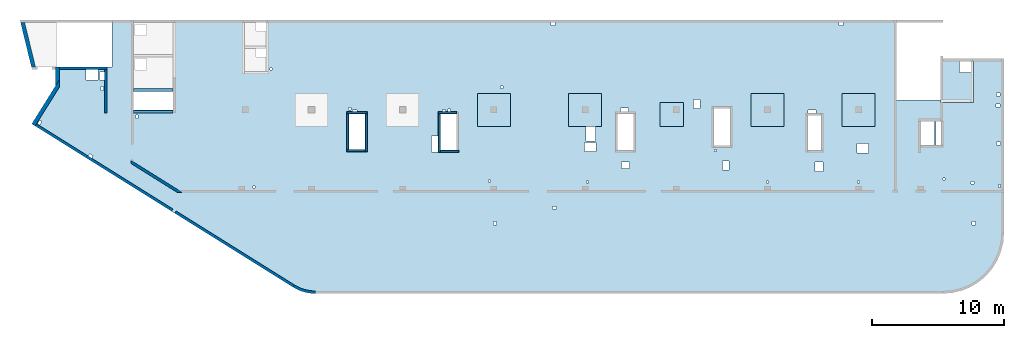
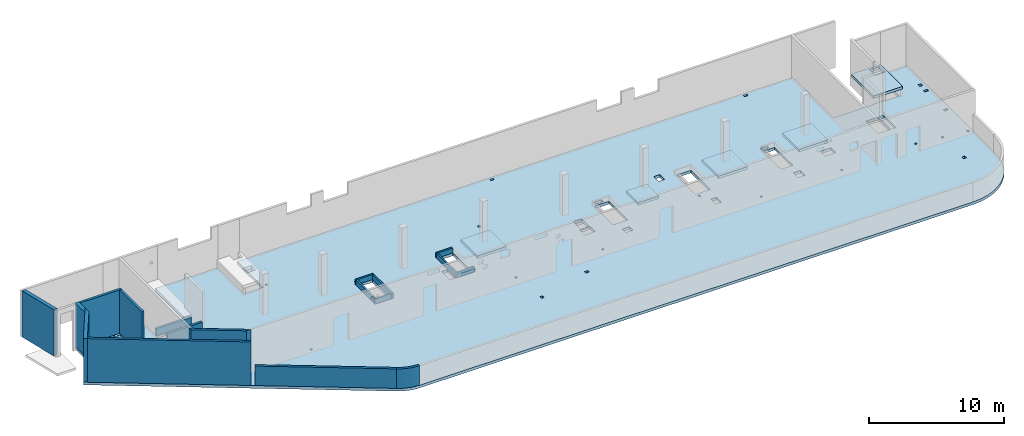
# One storey, part 2 of 6: 18 walls, 7 slabs.
"""IFC4 building model written with IfcOpenShell, lengths in millimetres."""

from ifc_helpers import new_model, entity, si_unit, converted_unit, derived_unit, direction, frame, origin, place, context, subcontext, project, spatial, indexed_curve, outline, extrude, material, type_object, element, save


model = new_model("IFC4")

# Units and contexts
model_context = context("Model", 3, precision=0.01, world=origin(), true_north=direction((6.12303176911189e-17, 1.0)))
plan_context = context("Plan", 3, precision=0.01, world=origin(), true_north=direction((6.12303176911189e-17, 1.0)))
body_context = subcontext(model_context, "Body", "Model", "MODEL_VIEW")
ifc_project = project(units=[si_unit("LENGTHUNIT", "METRE", prefix="MILLI"), si_unit("AREAUNIT", "SQUARE_METRE"), si_unit("VOLUMEUNIT", "CUBIC_METRE"), converted_unit("PLANEANGLEUNIT", "DEGREE", entity("IfcRatioMeasure", 0.0174532925199433), si_unit("PLANEANGLEUNIT", "RADIAN"), dimensions=[0, 0, 0, 0, 0, 0, 0]), si_unit("MASSUNIT", "GRAM", prefix="KILO"), derived_unit("MASSDENSITYUNIT", [(si_unit("MASSUNIT", "GRAM", prefix="KILO"), 1), (si_unit("LENGTHUNIT", "METRE"), -3)]), derived_unit("MOMENTOFINERTIAUNIT", [(si_unit("LENGTHUNIT", "METRE"), 4)]), si_unit("TIMEUNIT", "SECOND"), si_unit("FREQUENCYUNIT", "HERTZ"), si_unit("THERMODYNAMICTEMPERATUREUNIT", "DEGREE_CELSIUS"), derived_unit("THERMALTRANSMITTANCEUNIT", [(si_unit("MASSUNIT", "GRAM", prefix="KILO"), 1), (si_unit("THERMODYNAMICTEMPERATUREUNIT", "KELVIN"), -1), (si_unit("TIMEUNIT", "SECOND"), -3)]), derived_unit("VOLUMETRICFLOWRATEUNIT", [(si_unit("LENGTHUNIT", "METRE"), 3), (si_unit("TIMEUNIT", "SECOND"), -1)]), derived_unit("MASSFLOWRATEUNIT", [(si_unit("MASSUNIT", "GRAM", prefix="KILO"), 1), (si_unit("TIMEUNIT", "SECOND"), -1)]), derived_unit("ROTATIONALFREQUENCYUNIT", [(si_unit("TIMEUNIT", "SECOND"), -1)]), si_unit("ELECTRICCURRENTUNIT", "AMPERE"), si_unit("ELECTRICVOLTAGEUNIT", "VOLT"), si_unit("POWERUNIT", "WATT"), si_unit("FORCEUNIT", "NEWTON", prefix="KILO"), si_unit("ILLUMINANCEUNIT", "LUX"), si_unit("LUMINOUSFLUXUNIT", "LUMEN"), si_unit("LUMINOUSINTENSITYUNIT", "CANDELA"), derived_unit("USERDEFINED", [(si_unit("MASSUNIT", "GRAM", prefix="KILO"), -1), (si_unit("LENGTHUNIT", "METRE"), -2), (si_unit("TIMEUNIT", "SECOND"), 3), (si_unit("LUMINOUSFLUXUNIT", "LUMEN"), 1)]), derived_unit("LINEARVELOCITYUNIT", [(si_unit("LENGTHUNIT", "METRE"), 1), (si_unit("TIMEUNIT", "SECOND"), -1)]), si_unit("PRESSUREUNIT", "PASCAL"), derived_unit("USERDEFINED", [(si_unit("LENGTHUNIT", "METRE"), -2), (si_unit("MASSUNIT", "GRAM", prefix="KILO"), 1), (si_unit("TIMEUNIT", "SECOND"), -2)]), derived_unit("LINEARFORCEUNIT", [(si_unit("MASSUNIT", "GRAM", prefix="KILO"), 1), (si_unit("LENGTHUNIT", "METRE"), 1), (si_unit("TIMEUNIT", "SECOND"), -2), (si_unit("LENGTHUNIT", "METRE"), -1)]), derived_unit("PLANARFORCEUNIT", [(si_unit("MASSUNIT", "GRAM", prefix="KILO"), 1), (si_unit("LENGTHUNIT", "METRE"), 1), (si_unit("TIMEUNIT", "SECOND"), -2), (si_unit("LENGTHUNIT", "METRE"), -2)])], contexts=[model_context, plan_context])

# Site, building, storey
site_placement = place(None, origin())
site = spatial("IfcSite", under=ifc_project, at=site_placement, CompositionType="ELEMENT")
building_placement = place(site_placement, origin())
building = spatial("IfcBuilding", under=site, at=building_placement, CompositionType="ELEMENT")
storey_placement = place(building_placement, frame((0.0, 0.0, 28200.0)))
storey = spatial("IfcBuildingStorey", under=building, at=storey_placement, Name="08", CompositionType="ELEMENT", Elevation=28200.0)

# Slabs
ifc_material = material()
slab_type_1 = type_object("IfcSlabType", Name=":ADSK_ 25_250", PredefinedType="FLOOR", material=ifc_material)
placement = place(storey_placement, origin())
element("IfcSlab", 1, at=placement, inside=storey, type_object=slab_type_1, material=ifc_material, Name=":ADSK_ 25_250", ObjectType=":ADSK_ 25_250", PredefinedType="FLOOR", context=body_context, shape_type="SweptSolid", body=[
    extrude(outline(indexed_curve([(-9938.81931383592, -15994.6889933943), (-9785.18945223826, -16084.8814308087), (-9626.77631531153, -16166.380438105), (-9464.0713398645, -16238.9331851656), (-9297.57927705262, -16302.3145953889), (-9127.81662651489, -16356.3280439333), (-8955.31003406395, -16400.8059676958), (-8780.59465790024, -16435.6103851342), (-8604.21250841868, -16460.6333243205), (-8426.71076675808, -16475.797157896), (-8248.64008730964, -16481.0548438912), (39261.8400680731, -16481.0548438912), (39981.4384793149, -16424.4212206982), (40683.3179894618, -16255.9148588784), (41350.1959955693, -15979.6849443003), (41965.6517478859, -15602.5331742155), (42514.530683209, -15133.7462768982), (42983.3175805262, -14584.8673415751), (43360.4693506111, -13969.4115892585), (43636.6992651892, -13302.533583151), (43805.205627009, -12600.6540730041), (43861.839250202, -11881.0556617623), (43861.839250202, 1288.94433823765), (41361.839250202, 1288.94433823766), (41361.839250202, -1811.05566176234), (39061.8400680731, -1811.05566176233), (39061.8400680731, -1851.05566176232), (35721.8400680731, -1851.05566176231), (35721.8400680732, 4218.94497760487), (-11983.1599319269, 4218.94497760503), (-11983.1599319269, 318.944338238026), (-13608.1599319269, 318.944338238032), (-13608.1599319269, 4218.94497760487), (-19008.1599319269, 4218.94497760488), (-19008.1599319269, -981.05502239514), (-22008.1599319269, -981.055022395131), (-22008.1599319269, 4218.94497760487), (-23638.1599319269, 4218.94497760487), (-23638.1599319269, 678.944338238106), (-27903.1599319269, 678.944338238122), (-27903.1599319269, -752.702496972901), (-29708.3002878078, -3641.58731781876), (-9938.81931383592, -15994.6889933943)], self_intersect=False), holes=[indexed_curve([(-24693.1599319269, 478.944338238115), (-24693.1599319269, -321.055661761885), (-25623.1599319269, -321.055661761885), (-25623.1599319269, 478.944338238115), (-24693.1599319269, 478.944338238115)], self_intersect=False), indexed_curve([(-24573.1599319269, -311.055661761892), (-24573.1599319269, 288.944338238108), (-24208.1599319269, 288.944338238108), (-24208.1599319269, -311.055661761892), (-24573.1599319269, -311.055661761892)], self_intersect=False), indexed_curve([(-24268.1599319269, -821.055661761893), (-24268.1599319269, -1121.05566176189), (-24468.1599319269, -1121.05566176189), (-24468.1599319269, -821.055661761893), (-24268.1599319269, -821.055661761893)], self_intersect=False), indexed_curve([(-29120.030322959, -3360.6274479853), (-28950.4197742035, -3466.6098132677), (-29109.3933221271, -3721.02563640098), (-29279.0038708826, -3615.04327111857), (-29120.030322959, -3360.6274479853)], self_intersect=False), indexed_curve([(-25332.3965852951, -5904.23328799078), (-25077.9807621618, -6063.20683591438), (-25183.9631274442, -6232.8173846699), (-25438.3789505775, -6073.84383674629), (-25332.3965852951, -5904.23328799078)], self_intersect=False), indexed_curve([(-21683.1599319269, -2966.05566176191), (-21683.1599319269, -3216.05566176191), (-21833.1599319269, -3216.05566176191), (-21833.1599319269, -2966.05566176191), (-21683.1599319269, -2966.05566176191)], self_intersect=False), indexed_curve([(-11548.1599319269, 573.944338238028), (-11548.1599319269, 423.944338238028), (-11698.1599319269, 423.944338238028), (-11698.1599319269, 573.944338238028), (-11548.1599319269, 573.944338238028)], self_intersect=False), indexed_curve([(43571.839250202, -2146.05566176235), (43571.839250202, -2346.05566176235), (43271.839250202, -2346.05566176235), (43271.839250202, -2146.05566176236), (43571.839250202, -2146.05566176235)], self_intersect=False), indexed_curve([(43561.839250202, -1291.05566176236), (43561.839250202, -1541.05566176236), (43311.839250202, -1541.05566176235), (43311.839250202, -1291.05566176236), (43561.839250202, -1291.05566176236)], self_intersect=False), indexed_curve([(43611.839250202, -5031.05566176235), (43611.839250202, -5231.05566176235), (43311.839250202, -5231.05566176235), (43311.839250202, -5031.05566176235), (43611.839250202, -5031.05566176235)], self_intersect=False), indexed_curve([(43586.839250202, -8246.05566176236), (43586.839250202, -8446.05566176236), (43436.839250202, -8446.05566176236), (43436.839250202, -8246.05566176236), (43586.839250202, -8246.05566176236)], self_intersect=False), indexed_curve([(41581.839250202, -7991.05566176235), (41581.839250202, -8191.05566176235), (41381.839250202, -8191.05566176235), (41381.839250202, -7991.05566176235), (41581.839250202, -7991.05566176235)], self_intersect=False), indexed_curve([(39396.8400680731, -7746.05566176233), (39396.8400680731, -7896.05566176233), (39246.8400680731, -7896.05566176233), (39246.8400680731, -7746.05566176233), (39396.8400680731, -7746.05566176233)], self_intersect=False), indexed_curve([(41686.839250202, -11031.0556617623), (41686.839250202, -11281.0556617623), (41436.839250202, -11281.0556617623), (41436.839250202, -11031.0556617623), (41686.839250202, -11031.0556617623)], self_intersect=False), indexed_curve([(5461.84006807309, -11031.0556617622), (5461.84006807309, -11281.0556617622), (5211.84006807308, -11281.0556617622), (5211.84006807309, -11031.0556617622), (5461.84006807309, -11031.0556617622)], self_intersect=False), indexed_curve([(10011.8400680731, -9881.05566176212), (10011.8400680731, -10081.0556617621), (9711.84006807309, -10081.0556617621), (9711.84006807309, -9881.05566176212), (10011.8400680731, -9881.05566176212)], self_intersect=False), indexed_curve([(32936.8400680731, -8101.05566176228), (32786.8400680731, -8101.05566176228), (32786.8400680731, -7951.05566176228), (32936.8400680731, -7951.05566176228), (32936.8400680731, -8101.05566176228)], self_intersect=False), indexed_curve([(33621.8400680731, -5141.05566176228), (33621.8400680731, -5841.05566176228), (32721.8400680731, -5841.05566176228), (32721.8400680731, -5141.05566176227), (33621.8400680731, -5141.05566176228)], self_intersect=False), indexed_curve([(30166.8400680731, -6541.05566176228), (30166.8400680731, -7241.05566176228), (29566.8400680731, -7241.05566176227), (29566.8400680731, -6541.05566176227), (30166.8400680731, -6541.05566176228)], self_intersect=False), indexed_curve([(26036.8400680731, -8101.05566176226), (25886.8400680731, -8101.05566176226), (25886.8400680731, -7951.05566176226), (26036.8400680731, -7951.05566176226), (26036.8400680731, -8101.05566176226)], self_intersect=False), indexed_curve([(12411.8400680731, -8121.05566176221), (12261.8400680731, -8121.05566176222), (12261.8400680731, -7971.05566176221), (12411.8400680731, -7971.05566176221), (12411.8400680731, -8121.05566176221)], self_intersect=False), indexed_curve([(5001.8400680731, -8041.05566176219), (4851.84006807309, -8041.05566176219), (4851.84006807309, -7891.05566176219), (5001.84006807309, -7891.05566176219), (5001.8400680731, -8041.05566176219)], self_intersect=False), indexed_curve([(-12818.1599319269, -8506.05566176197), (-12968.1599319269, -8506.05566176196), (-12968.1599319269, -8356.05566176196), (-12818.1599319269, -8356.05566176196), (-12818.1599319269, -8506.05566176197)], self_intersect=False), indexed_curve([(29021.8400680731, -5656.05566176226), (29021.8400680731, -2986.05566176226), (30021.8400680731, -2986.05566176226), (30021.8400680731, -5656.05566176226), (29021.8400680731, -5656.05566176226)], self_intersect=False), indexed_curve([(29021.8400680731, -2581.05566176225), (29621.8400680731, -2581.05566176225), (29621.8400680731, -2836.05566176225), (29021.8400680731, -2836.05566176226), (29021.8400680731, -2581.05566176225)], self_intersect=False), indexed_curve([(23041.8400680731, -6446.05566176221), (23041.8400680731, -7146.05566176222), (22541.8400680731, -7146.05566176222), (22541.8400680731, -6446.05566176221), (23041.8400680731, -6446.05566176221)], self_intersect=False), indexed_curve([(22096.8400680731, -5571.05566176221), (22096.8400680731, -5721.05566176221), (21946.8400680731, -5721.05566176221), (21946.8400680731, -5571.05566176221), (22096.8400680731, -5571.05566176221)], self_intersect=False), indexed_curve([(23141.8400680731, -2446.05566176221), (23141.8400680731, -5306.05566176222), (21881.8400680731, -5306.05566176221), (21881.8400680731, -2446.0556617622), (23141.8400680731, -2446.05566176221)], self_intersect=False), indexed_curve([(38611.8400680731, -3451.05566176231), (38611.8400680731, -5256.05566176231), (37571.8400680731, -5256.05566176231), (37571.8400680731, -3451.05566176231), (38611.8400680731, -3451.05566176231)], self_intersect=False), indexed_curve([(39111.8400680731, -3451.05566176232), (39111.8400680731, -5256.05566176232), (38731.8400680731, -5256.05566176232), (38731.8400680731, -3451.05566176232), (39061.8400680731, -3451.05566176232), (39111.8400680731, -3451.05566176232)], self_intersect=False), indexed_curve([(-4458.15993192693, -2881.05566176151), (-4458.15993192693, -5591.05566176151), (-5718.15993192693, -5591.05566176151), (-5718.15993192693, -2881.05566176151), (-4458.15993192693, -2881.05566176151)], self_intersect=False), indexed_curve([(-5088.15993192693, -2581.05566176152), (-5088.15993192693, -2731.05566176152), (-5438.15993192692, -2731.05566176152), (-5438.15993192693, -2581.05566176151), (-5088.15993192693, -2581.05566176152)], self_intersect=False), indexed_curve([(-5538.15993192693, -2391.05566176151), (-5538.15993192693, -2591.05566176151), (-5738.15993192693, -2591.05566176151), (-5738.15993192693, -2391.05566176151), (-5538.15993192693, -2391.05566176151)], self_intersect=False), indexed_curve([(1616.84006807306, -2561.05566176154), (1616.84006807306, -2711.05566176153), (1366.84006807306, -2711.05566176153), (1366.84006807306, -2561.05566176153), (1616.84006807306, -2561.05566176154)], self_intersect=False), indexed_curve([(2461.84006807306, -2881.05566176156), (2461.84006807306, -5656.05566176156), (1201.84006807306, -5656.05566176156), (1201.84006807307, -2881.05566176156), (2461.84006807306, -2881.05566176156)], self_intersect=False), indexed_curve([(1981.84006807306, -2531.05566176156), (1981.84006807306, -2731.05566176156), (1781.84006807306, -2731.05566176156), (1781.84006807306, -2531.05566176156), (1981.84006807306, -2531.05566176156)], self_intersect=False), indexed_curve([(1031.84006807307, -4561.05566176155), (1031.84006807307, -5761.05566176155), (531.840068073072, -5761.05566176155), (531.840068073072, -4561.05566176155), (1031.84006807307, -4561.05566176155)], self_intersect=False), indexed_curve([(5961.84006807306, -771.055661761588), (5961.84006807306, -971.055661761588), (5761.84006807306, -971.055661761592), (5761.84006807306, -771.05566176159), (5961.84006807306, -771.055661761588)], self_intersect=False), indexed_curve([(12946.8400680731, -3831.05566176163), (12946.8400680731, -4951.05566176164), (12246.8400680731, -4951.05566176163), (12246.8400680731, -3831.05566176163), (12946.8400680731, -3831.05566176163)], self_intersect=False), indexed_curve([(13001.8400680731, -5046.05566176163), (13001.8400680731, -5746.05566176164), (12101.8400680731, -5746.05566176163), (12101.8400680731, -5046.05566176163), (13001.8400680731, -5046.05566176163)], self_intersect=False), indexed_curve([(15861.8400680731, -2881.05566176161), (15861.8400680731, -5656.05566176161), (14601.8400680731, -5656.05566176161), (14601.8400680731, -2881.05566176162), (15861.8400680731, -2881.05566176161)], self_intersect=False), indexed_curve([(15461.8400680731, -2451.05566176165), (15461.8400680731, -2731.05566176162), (14831.8400680731, -2731.05566176162), (14831.8400680731, -2451.05566176165), (15461.8400680731, -2451.05566176165)], self_intersect=False), indexed_curve([(15516.8400680731, -6511.05566176205), (15516.8400680731, -7011.05566176205), (14916.8400680731, -7011.05566176205), (14916.8400680731, -6511.05566176205), (15516.8400680731, -6511.05566176205)], self_intersect=False), indexed_curve([(20856.8400680731, -1786.05566176169), (20856.8400680731, -2486.05566176169), (20356.8400680731, -2486.05566176169), (20356.8400680731, -1786.0556617617), (20856.8400680731, -1786.05566176169)], self_intersect=False), indexed_curve([(9891.84006807312, 4018.94497760487), (9891.84006807312, 3818.94497760487), (9591.84006807312, 3818.94497760487), (9591.84006807312, 4018.94497760487), (9891.84006807312, 4018.94497760487)], self_intersect=False), indexed_curve([(31661.8400680731, 4018.944977605), (31661.8400680731, 3818.94497760499), (31361.8400680731, 3818.94497760499), (31361.8400680731, 4018.94497760499), (31661.8400680731, 4018.944977605)], self_intersect=False), indexed_curve([(-19008.1599319269, -1181.05502239513), (-19008.1599319269, -2581.05502239513), (-22008.1599319269, -2581.05502239513), (-22008.1599319269, -1181.05502239513), (-19008.1599319269, -1181.05502239513)], self_intersect=False)]), frame((29708.16, 16281.05, -400.0)), (0.0, 0.0, 1.0), 249.999999999999),
])
slab_type_2 = type_object("IfcSlabType", Name=":ADSK_ 25_250", PredefinedType="FLOOR", material=ifc_material)
element("IfcSlab", 2, at=placement, inside=storey, type_object=slab_type_2, material=ifc_material, Name=":ADSK_ 25_250", ObjectType=":ADSK_ 25_250", PredefinedType="FLOOR", context=body_context, shape_type="SweptSolid", body=[
    extrude(outline(indexed_curve([(-1133.33296983506, -1466.66666666666), (-933.332969835079, -1466.66666666666), (1166.66621229381, -1466.66666666666), (1366.66621229383, -1466.66666666666), (1366.66621229383, 1633.33333333332), (1366.66621229383, 1833.33333333332), (-933.33296983507, 1833.33333333332), (-1133.33296983506, 1833.33333333332), (-1133.33296983506, -1266.66666666668), (-1133.33296983506, -1466.66666666666)], self_intersect=False), holes=[indexed_curve([(-933.33296983507, -1266.66666666667), (-933.33296983507, -416.666666666674), (-83.332969835073, -416.666666666674), (-83.332969835073, -1266.66666666667), (-933.33296983507, -1266.66666666667)], self_intersect=False)]), frame((70136.67, 16103.33, 500.0), z_axis=(0.0, 0.0, 1.0), x_axis=(-1.0, 0.0, 0.0)), (0.0, 0.0, 1.0), 249.999999999999),
])
slab_type_3 = type_object("IfcSlabType", Name=":ADSK_ 25_250", PredefinedType="FLOOR", material=ifc_material)
element("IfcSlab", 3, at=placement, inside=storey, type_object=slab_type_3, material=ifc_material, Name=":ADSK_ 25_250", ObjectType=":ADSK_ 25_250", PredefinedType="FLOOR", context=body_context, shape_type="SweptSolid", body=[
    extrude(outline(indexed_curve([(-1250.0, -1250.0), (1250.0, -1250.0), (1250.0, 1250.0), (-1250.0, 1250.0), (-1250.0, -1250.0)], self_intersect=False)), frame((34970.0, 13700.0, -400.0), z_axis=(0.0, 0.0, -1.0), x_axis=(0.0, 1.0, 0.0)), (0.0, 0.0, 1.0), 249.999999999999),
])
slab_type_4 = type_object("IfcSlabType", Name=":ADSK_ 25_250", PredefinedType="FLOOR", material=ifc_material)
element("IfcSlab", 4, at=placement, inside=storey, type_object=slab_type_4, material=ifc_material, Name=":ADSK_ 25_250", ObjectType=":ADSK_ 25_250", PredefinedType="FLOOR", context=body_context, shape_type="SweptSolid", body=[
    extrude(outline(indexed_curve([(-1250.0, -1250.0), (1250.0, -1250.0), (1250.0, 1250.0), (-1250.0, 1250.0), (-1250.0, -1250.0)], self_intersect=False)), frame((41870.0, 13700.0, -400.0), z_axis=(0.0, 0.0, -1.0), x_axis=(0.0, 1.0, 0.0)), (0.0, 0.0, 1.0), 249.999999999999),
])
slab_type_5 = type_object("IfcSlabType", Name=":ADSK_ 25_250", PredefinedType="FLOOR", material=ifc_material)
element("IfcSlab", 5, at=placement, inside=storey, type_object=slab_type_5, material=ifc_material, Name=":ADSK_ 25_250", ObjectType=":ADSK_ 25_250", PredefinedType="FLOOR", context=body_context, shape_type="SweptSolid", body=[
    extrude(outline(indexed_curve([(-899.999999999934, -900.000000000003), (899.999999999936, -900.000000000003), (899.999999999936, 900.000000000003), (-899.999999999934, 900.000000000003), (-899.999999999934, -900.000000000003)], self_intersect=False)), frame((48420.0, 13350.0, -400.0), z_axis=(0.0, 0.0, -1.0), x_axis=(0.0, 1.0, 0.0)), (0.0, 0.0, 1.0), 249.999999999999),
])
slab_type_6 = type_object("IfcSlabType", Name=":ADSK_ 25_250", PredefinedType="FLOOR", material=ifc_material)
element("IfcSlab", 6, at=placement, inside=storey, type_object=slab_type_6, material=ifc_material, Name=":ADSK_ 25_250", ObjectType=":ADSK_ 25_250", PredefinedType="FLOOR", context=body_context, shape_type="SweptSolid", body=[
    extrude(outline(indexed_curve([(-1250.0, -1250.00000000001), (1250.0, -1250.00000000001), (1250.0, 1249.99999999999), (-1250.0, 1249.99999999999), (-1250.0, -1250.00000000001)], self_intersect=False)), frame((55670.0, 13700.0, -400.0), z_axis=(0.0, 0.0, -1.0), x_axis=(0.0, 1.0, 0.0)), (0.0, 0.0, 1.0), 249.999999999999),
])
slab_type_7 = type_object("IfcSlabType", Name=":ADSK_ 25_250", PredefinedType="FLOOR", material=ifc_material)
element("IfcSlab", 7, at=placement, inside=storey, type_object=slab_type_7, material=ifc_material, Name=":ADSK_ 25_250", ObjectType=":ADSK_ 25_250", PredefinedType="FLOOR", context=body_context, shape_type="SweptSolid", body=[
    extrude(outline(indexed_curve([(-1250.0, -1249.99999999999), (1250.0, -1249.99999999999), (1250.0, 1250.00000000001), (-1250.0, 1250.00000000001), (-1250.0, -1249.99999999999)], self_intersect=False)), frame((62570.0, 13700.0, -400.0), z_axis=(0.0, 0.0, -1.0), x_axis=(0.0, 1.0, 0.0)), (0.0, 0.0, 1.0), 249.999999999999),
])

# Walls
wall_type_1 = type_object("IfcWallType", Name=":ADSK_ 25_200", PredefinedType="STANDARD")
wall_1_placement = place(storey_placement, frame((2105.0, 16860.0, -150.0)))
element("IfcWall", 8, at=wall_1_placement, inside=storey, type_object=wall_type_1, material=ifc_material, Name=":ADSK_ 25_200", ObjectType=":ADSK_ 25_200", PredefinedType="NOTDEFINED", context=body_context, shape_type="SweptSolid", body=[
    extrude(outline(indexed_curve([(3595.0, 99.9999999999979), (-6.29008184861995e-14, 99.9999999999989), (6.29008184861995e-14, -99.9999999999989), (3595.0, -99.9999999999999), (3595.0, 99.9999999999979)], self_intersect=False)), origin(), (0.0, 0.0, 1.0), 3950.0),
])
wall_2_placement = place(storey_placement, frame((5600.0, 16760.0, -150.0), z_axis=(0.0, 0.0, 1.0), x_axis=(0.0, -1.0, 0.0)))
element("IfcWall", 9, at=wall_2_placement, inside=storey, type_object=wall_type_1, material=ifc_material, Name=":ADSK_ 25_200", ObjectType=":ADSK_ 25_200", PredefinedType="NOTDEFINED", context=body_context, shape_type="SweptSolid", body=[
    extrude(outline(indexed_curve([(3310.00000000004, 99.9999999999997), (-1.54254576823131e-13, 100.0), (1.54254576823131e-13, -100.0), (3310.00000000004, -100.0), (3310.00000000004, 99.9999999999997)], self_intersect=False)), origin(), (0.0, 0.0, 1.0), 3950.0),
])
wall_3_placement = place(storey_placement, frame((307.27, 12565.3, -150.0), z_axis=(0.0, 0.0, 1.0), x_axis=(0.848052743777574, -0.529911826412026, 0.0)))
element("IfcWall", 10, at=wall_3_placement, inside=storey, type_object=wall_type_1, material=ifc_material, Name=":ADSK_ 25_200", ObjectType=":ADSK_ 25_200", PredefinedType="NOTDEFINED", context=body_context, shape_type="SweptSolid", body=[
    extrude(outline(indexed_curve([(12172.7700242045, 100.000000000001), (-2.62256882876955e-13, 100.0), (3.2147617901046e-13, -100.0), (12172.7700242045, -100.0), (12172.7700242045, 100.000000000001)], self_intersect=False)), origin(), (0.0, 0.0, 1.0), 3950.0),
])
wall_4_placement = place(storey_placement, frame((7447.01, 9790.2, -150.0), z_axis=(0.0, 0.0, 1.0), x_axis=(0.848052743777574, -0.529911826412026, 0.0)))
element("IfcWall", 11, at=wall_4_placement, inside=storey, type_object=wall_type_1, material=ifc_material, Name=":ADSK_ 25_200", ObjectType=":ADSK_ 25_200", PredefinedType="NOTDEFINED", context=body_context, shape_type="SweptSolid", body=[
    extrude(outline(indexed_curve([(4256.16407725215, -99.9999999999989), (4576.23722961777, 100.000000000002), (4198.81594926216, 100.000000000002), (235.834388211653, 100.000000000003), (-9.47508738136094e-13, 100.000000000003), (124.971431388001, -99.9999999999987), (4256.16407725215, -99.9999999999989)], self_intersect=False)), origin(), (0.0, 0.0, 1.0), 3950.0),
])
wall_5_placement = place(storey_placement, frame((10875.26, 5961.81, -150.0), z_axis=(0.0, 0.0, 1.0), x_axis=(0.848052743777574, -0.529911826412025, 0.0)))
element("IfcWall", 12, at=wall_5_placement, inside=storey, type_object=wall_type_1, material=ifc_material, Name=":ADSK_ 25_200", ObjectType=":ADSK_ 25_200", PredefinedType="NOTDEFINED", context=body_context, shape_type="SweptSolid", body=[
    extrude(outline(indexed_curve([(10550.8352599265, 99.9999999999989), (-7.02171654154427e-13, 100.0), (7.02171654154427e-13, -100.0), (10550.8352599265, -100.000000000002), (10550.8352599265, 99.9999999999989)], self_intersect=False)), origin(), (0.0, 0.0, 1.0), 1770.0),
])
wall_6_placement = place(storey_placement, frame((19822.92, 370.8, -150.0)))
element("IfcWall", 13, at=wall_6_placement, inside=storey, type_object=wall_type_1, material=ifc_material, Name=":ADSK_ 25_200", ObjectType=":ADSK_ 25_200", PredefinedType="NOTDEFINED", context=body_context, shape_type="SweptSolid", body=[
    extrude(outline(indexed_curve([(1641.92023350293, -370.805258501397), (1474.54329430422, -366.130070716584), (1307.68829895409, -352.119086344867), (1141.87556368517, -328.81599687171), (977.622154573621, -296.293470038928), (815.4402751339, -254.652923239516), (655.835669076768, -204.024207260316), (499.306043211407, -144.565201358734), (346.339515409568, -76.4613209362117), (197.413092471656, 0.0750606562846201), (52.9911826412194, 84.805274377746), (-52.991182641202, -84.8052743777568), (101.063741069954, -175.187035886212), (259.923631173975, -256.828432549666), (423.093103164338, -329.47487598227), (590.063333647626, -392.899827423948), (760.31364704501, -446.905504172905), (933.313139253311, -491.323496346018), (1108.52233320239, -526.015292043783), (1285.39486114626, -550.872709282183), (1463.37916844194, -565.818233344545), (1641.92023350291, -570.805258501397), (1641.92023350293, -370.805258501397)], self_intersect=False)), origin(), (0.0, 0.0, 1.0), 1770.0),
])
wall_7_placement = place(storey_placement, frame((7700.0, 15200.0, -150.0)))
element("IfcWall", 14, at=wall_7_placement, inside=storey, type_object=wall_type_1, material=ifc_material, Name=":ADSK_ 25_200", ObjectType=":ADSK_ 25_200", PredefinedType="NOTDEFINED", context=body_context, shape_type="SweptSolid", body=[
    extrude(outline(indexed_curve([(2999.99999999999, 99.9999999999989), (-2.88764567812902e-13, 99.9999999999989), (2.88764567812902e-13, -99.9999999999989), (2999.99999999999, -99.9999999999989), (2999.99999999999, 99.9999999999989)], self_intersect=False)), origin(), (0.0, 0.0, 1.0), 650.0),
])
wall_8_placement = place(storey_placement, frame((10700.0, 13550.0, -150.0), z_axis=(0.0, 0.0, 1.0), x_axis=(-1.0, 0.0, 0.0)))
element("IfcWall", 15, at=wall_8_placement, inside=storey, type_object=wall_type_1, material=ifc_material, Name=":ADSK_ 25_200", ObjectType=":ADSK_ 25_200", PredefinedType="NOTDEFINED", context=body_context, shape_type="SweptSolid", body=[
    extrude(outline(indexed_curve([(3000.0, 99.9999999999984), (-3.44878351568426e-13, 99.9999999999989), (3.44878351568426e-13, -99.9999999999989), (3000.0, -99.9999999999994), (3000.0, 99.9999999999984)], self_intersect=False)), origin(), (0.0, 0.0, 1.0), 1200.0),
])
wall_type_2 = type_object("IfcWallType", Name=":ADSK_ 25_300", PredefinedType="STANDARD")
wall_9_placement = place(storey_placement, frame((127.07, 12559.98, -150.0), z_axis=(0.0, 0.0, 1.0), x_axis=(0.529911826412024, 0.848052743777575, 0.0)))
element("IfcWall", 16, at=wall_9_placement, inside=storey, type_object=wall_type_2, material=ifc_material, Name=":ADSK_ 25_300", ObjectType=":ADSK_ 25_300", PredefinedType="NOTDEFINED", context=body_context, shape_type="SweptSolid", body=[
    extrude(outline(indexed_curve([(3492.51411367559, -150.0), (3972.62384222401, 150.0), (3406.49192169061, 150.000000000001), (1.99653626964391e-12, 150.0), (3.2147617901046e-13, -150.0), (200.000000000003, -149.999999999999), (3492.51411367559, -150.0)], self_intersect=False)), origin(), (0.0, 0.0, 1.0), 3950.0),
])
wall_10_placement = place(storey_placement, frame((1955.0, 15528.35, -150.0), z_axis=(0.0, 0.0, 1.0), x_axis=(0.0, 1.0, 0.0)))
element("IfcWall", 17, at=wall_10_placement, inside=storey, type_object=wall_type_2, material=ifc_material, Name=":ADSK_ 25_300", ObjectType=":ADSK_ 25_300", PredefinedType="NOTDEFINED", context=body_context, shape_type="SweptSolid", body=[
    extrude(outline(indexed_curve([(1431.64683521101, -150.0), (1431.64683521101, 150.0), (-2.46541530600305e-13, 150.0), (480.109728548418, -150.0), (1231.64683521101, -150.0), (1431.64683521101, -150.0)], self_intersect=False)), origin(), (0.0, 0.0, 1.0), 3950.0),
])
wall_11_placement = place(storey_placement, frame((133.59, 16924.48, -400.0), z_axis=(0.0, 0.0, 1.0), x_axis=(-0.236826092990336, 0.971552058141473, 0.0)))
element("IfcWall", 18, at=wall_11_placement, inside=storey, type_object=wall_type_2, material=ifc_material, Name=":ADSK_ 25_300", ObjectType=":ADSK_ 25_300", PredefinedType="NOTDEFINED", context=body_context, shape_type="SweptSolid", body=[
    extrude(outline(indexed_curve([(3437.79894384249, -150.0), (3510.92711777998, 150.0), (73.1281739374955, 150.0), (7.65620900011754e-13, -150.0), (3437.79894384249, -150.0)], self_intersect=False)), origin(), (0.0, 0.0, 1.0), 4200.0),
])
wall_type_3 = type_object("IfcWallType", Name=":ADSK_ 25_150", PredefinedType="STANDARD")
wall_12_placement = place(storey_placement, frame((23840.0, 13475.0, -150.0)))
element("IfcWall", 19, at=wall_12_placement, inside=storey, type_object=wall_type_3, material=ifc_material, Name=":ADSK_ 25_150", ObjectType=":ADSK_ 25_150", PredefinedType="NOTDEFINED", context=body_context, shape_type="SweptSolid", body=[
    extrude(outline(indexed_curve([(1560.0, 75.0000000000013), (-2.57825506975809e-13, 75.0000000000003), (2.57825506975809e-13, -75.0000000000003), (1560.0, -74.9999999999992), (1560.0, 75.0000000000013)], self_intersect=False)), origin(), (0.0, 0.0, 1.0), 450.000000000002),
])
wall_13_placement = place(storey_placement, frame((25325.0, 13400.0, -150.0), z_axis=(0.0, 0.0, 1.0), x_axis=(0.0, -1.0, 0.0)))
element("IfcWall", 20, at=wall_13_placement, inside=storey, type_object=wall_type_3, material=ifc_material, Name=":ADSK_ 25_150", ObjectType=":ADSK_ 25_150", PredefinedType="NOTDEFINED", context=body_context, shape_type="SweptSolid", body=[
    extrude(outline(indexed_curve([(2859.99999999999, 75.0000000000005), (-1.19874589959232e-13, 75.0000000000003), (1.19874589959232e-13, -75.0000000000003), (2859.99999999999, -75.0), (2859.99999999999, 75.0000000000005)], self_intersect=False)), origin(), (0.0, 0.0, 1.0), 450.000000000002),
])
wall_14_placement = place(storey_placement, frame((25250.0, 10615.0, -150.0), z_axis=(0.0, 0.0, 1.0), x_axis=(-1.0, 0.0, 0.0)))
element("IfcWall", 21, at=wall_14_placement, inside=storey, type_object=wall_type_3, material=ifc_material, Name=":ADSK_ 25_150", ObjectType=":ADSK_ 25_150", PredefinedType="NOTDEFINED", context=body_context, shape_type="SweptSolid", body=[
    extrude(outline(indexed_curve([(1410.0, 75.0000000000008), (-2.5782550697581e-13, 75.0000000000003), (2.5782550697581e-13, -75.0000000000003), (1410.0, -74.9999999999998), (1410.0, 75.0000000000008)], self_intersect=False)), origin(), (0.0, 0.0, 1.0), 450.000000000002),
])
wall_15_placement = place(storey_placement, frame((23915.0, 10690.0, -150.0), z_axis=(0.0, 0.0, 1.0), x_axis=(0.0, 1.0, 0.0)))
element("IfcWall", 22, at=wall_15_placement, inside=storey, type_object=wall_type_3, material=ifc_material, Name=":ADSK_ 25_150", ObjectType=":ADSK_ 25_150", PredefinedType="NOTDEFINED", context=body_context, shape_type="SweptSolid", body=[
    extrude(outline(indexed_curve([(2709.99999999999, 75.0000000000003), (0.0, 75.0000000000003), (0.0, -75.0000000000003), (2709.99999999999, -75.0000000000003), (2709.99999999999, 75.0000000000003)], self_intersect=False)), origin(), (0.0, 0.0, 1.0), 450.000000000002),
])
wall_16_placement = place(storey_placement, frame((30760.0, 13475.0, -150.0)))
element("IfcWall", 23, at=wall_16_placement, inside=storey, type_object=wall_type_3, material=ifc_material, Name=":ADSK_ 25_150", ObjectType=":ADSK_ 25_150", PredefinedType="NOTDEFINED", context=body_context, shape_type="SweptSolid", body=[
    extrude(outline(indexed_curve([(1410.0, 75.0000000000003), (0.0, 75.0000000000003), (0.0, -75.0000000000003), (1410.0, -75.0000000000003), (1410.0, 75.0000000000003)], self_intersect=False)), origin(), (0.0, 0.0, 1.0), 450.000000000002),
])
wall_17_placement = place(storey_placement, frame((30835.0, 10475.0, -150.0), z_axis=(0.0, 0.0, 1.0), x_axis=(0.0, 1.0, 0.0)))
element("IfcWall", 24, at=wall_17_placement, inside=storey, type_object=wall_type_3, material=ifc_material, Name=":ADSK_ 25_150", ObjectType=":ADSK_ 25_150", PredefinedType="NOTDEFINED", context=body_context, shape_type="SweptSolid", body=[
    extrude(outline(indexed_curve([(2925.0, 75.0000000000003), (0.0, 75.0000000000003), (0.0, -75.0000000000003), (2925.0, -75.0000000000003), (2925.0, 75.0000000000003)], self_intersect=False)), origin(), (0.0, 0.0, 1.0), 450.000000000002),
])
wall_18_placement = place(storey_placement, frame((32320.0, 10550.0, -150.0), z_axis=(0.0, 0.0, 1.0), x_axis=(-1.0, 0.0, 0.0)))
element("IfcWall", 25, at=wall_18_placement, inside=storey, type_object=wall_type_3, material=ifc_material, Name=":ADSK_ 25_150", ObjectType=":ADSK_ 25_150", PredefinedType="NOTDEFINED", context=body_context, shape_type="SweptSolid", body=[
    extrude(outline(indexed_curve([(1410.0, 75.0000000000003), (0.0, 75.0000000000003), (0.0, -75.0000000000003), (1410.0, -75.0000000000003), (1410.0, 75.0000000000003)], self_intersect=False)), origin(), (0.0, 0.0, 1.0), 450.000000000002),
])

save(model, "model.ifc")
